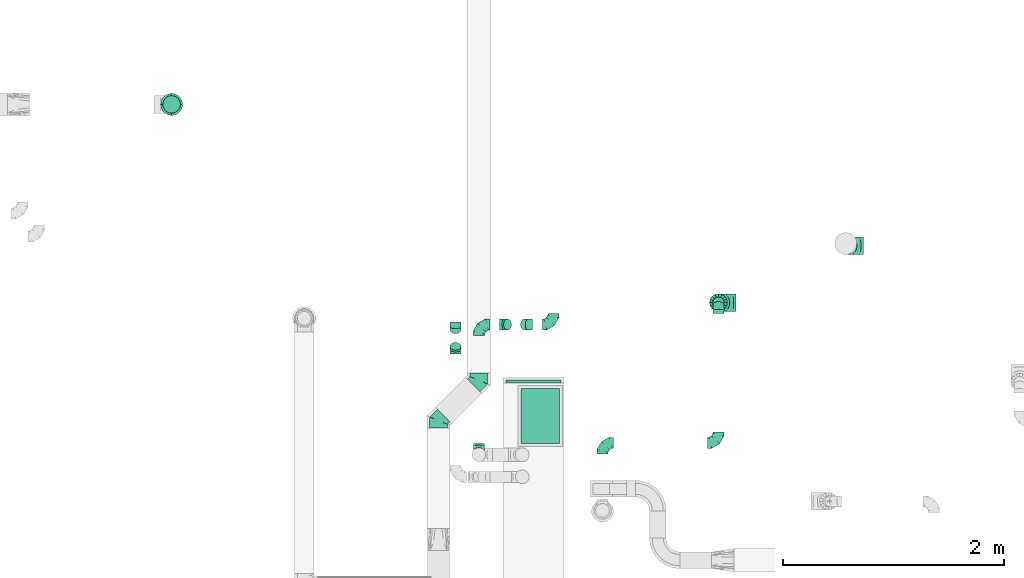
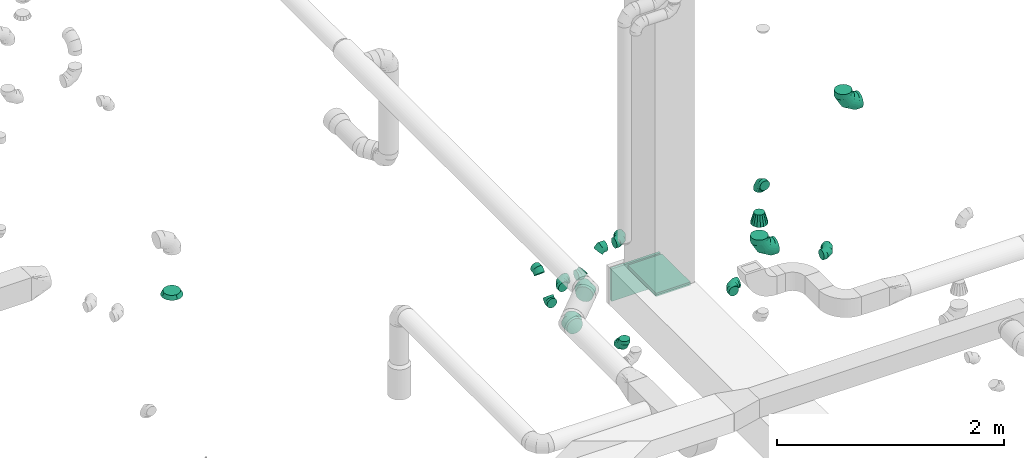
# One storey, part 76 of 97: 18 flow fittings.
"""IFC2X3 building model written with IfcOpenShell, lengths in millimetres."""

from ifc_helpers import new_model, entity, si_unit, converted_unit, derived_unit, direction, frame, origin, origin_2d_with_axis, place, context, subcontext, project, spatial, rectangle, extrude, faceted_brep, source, transform, mapped, material, type_object, type_shapes, element, save


model = new_model("IFC2X3")

# Units and contexts
model_context = context("Model", 3, precision=0.01, world=origin(), true_north=direction((6.12303176911189e-17, 1.0)))
body_context = subcontext(model_context, "Body", "Model", "MODEL_VIEW")
ifc_project = project(units=[si_unit("LENGTHUNIT", "METRE", prefix="MILLI"), si_unit("AREAUNIT", "SQUARE_METRE"), si_unit("VOLUMEUNIT", "CUBIC_METRE"), converted_unit("PLANEANGLEUNIT", "DEGREE", entity("IfcRatioMeasure", 0.0174532925199433), si_unit("PLANEANGLEUNIT", "RADIAN"), dimensions=[0, 0, 0, 0, 0, 0, 0]), si_unit("MASSUNIT", "GRAM", prefix="KILO"), derived_unit("MASSDENSITYUNIT", [(si_unit("MASSUNIT", "GRAM", prefix="KILO"), 1), (si_unit("LENGTHUNIT", "METRE"), -3)]), derived_unit("MOMENTOFINERTIAUNIT", [(si_unit("LENGTHUNIT", "METRE"), 4)]), si_unit("TIMEUNIT", "SECOND"), si_unit("FREQUENCYUNIT", "HERTZ"), si_unit("THERMODYNAMICTEMPERATUREUNIT", "DEGREE_CELSIUS"), derived_unit("THERMALTRANSMITTANCEUNIT", [(si_unit("MASSUNIT", "GRAM", prefix="KILO"), 1), (si_unit("THERMODYNAMICTEMPERATUREUNIT", "KELVIN"), -1), (si_unit("TIMEUNIT", "SECOND"), -3)]), derived_unit("VOLUMETRICFLOWRATEUNIT", [(si_unit("LENGTHUNIT", "METRE"), 3), (si_unit("TIMEUNIT", "SECOND"), -1)]), derived_unit("MASSFLOWRATEUNIT", [(si_unit("MASSUNIT", "GRAM", prefix="KILO"), 1), (si_unit("TIMEUNIT", "SECOND"), -1)]), derived_unit("ROTATIONALFREQUENCYUNIT", [(si_unit("TIMEUNIT", "SECOND"), -1)]), si_unit("ELECTRICCURRENTUNIT", "AMPERE"), si_unit("ELECTRICVOLTAGEUNIT", "VOLT"), si_unit("POWERUNIT", "WATT"), si_unit("FORCEUNIT", "NEWTON", prefix="KILO"), si_unit("ILLUMINANCEUNIT", "LUX"), si_unit("LUMINOUSFLUXUNIT", "LUMEN"), si_unit("LUMINOUSINTENSITYUNIT", "CANDELA"), derived_unit("USERDEFINED", [(si_unit("MASSUNIT", "GRAM", prefix="KILO"), -1), (si_unit("LENGTHUNIT", "METRE"), -2), (si_unit("TIMEUNIT", "SECOND"), 3), (si_unit("LUMINOUSFLUXUNIT", "LUMEN"), 1)]), derived_unit("LINEARVELOCITYUNIT", [(si_unit("LENGTHUNIT", "METRE"), 1), (si_unit("TIMEUNIT", "SECOND"), -1)]), si_unit("PRESSUREUNIT", "PASCAL"), derived_unit("USERDEFINED", [(si_unit("LENGTHUNIT", "METRE"), -2), (si_unit("MASSUNIT", "GRAM", prefix="KILO"), 1), (si_unit("TIMEUNIT", "SECOND"), -2)]), derived_unit("LINEARFORCEUNIT", [(si_unit("MASSUNIT", "GRAM", prefix="KILO"), 1), (si_unit("LENGTHUNIT", "METRE"), 1), (si_unit("TIMEUNIT", "SECOND"), -2), (si_unit("LENGTHUNIT", "METRE"), -1)]), derived_unit("PLANARFORCEUNIT", [(si_unit("MASSUNIT", "GRAM", prefix="KILO"), 1), (si_unit("LENGTHUNIT", "METRE"), 1), (si_unit("TIMEUNIT", "SECOND"), -2), (si_unit("LENGTHUNIT", "METRE"), -2)])], contexts=[model_context])

# Site, building, storey
site_placement = place(None, origin())
site = spatial("IfcSite", under=ifc_project, at=site_placement, CompositionType="ELEMENT")
building_placement = place(site_placement, origin())
building = spatial("IfcBuilding", under=site, at=building_placement, CompositionType="ELEMENT")
storey_placement = place(building_placement, frame((0.0, 0.0, -4900.0)))
storey = spatial("IfcBuildingStorey", under=building, at=storey_placement, CompositionType="ELEMENT", Elevation=-4900.0)

# Flow fittings
ifc_material = material()
duct_fitting_type_1 = type_object("IfcDuctFittingType", PredefinedType="NOTDEFINED", material=ifc_material)
shared_shape_1 = source(origin(), body_context, "Body", "SweptSolid", [
    extrude(rectangle(XDim=24.9999999999999, YDim=500.0, at=origin_2d_with_axis()), frame((12.5, 0.0, -175.0)), (0.0, 0.0, 1.0), 350.0),
])
type_shapes(duct_fitting_type_1, [shared_shape_1])
flow_fitting_1_placement = place(storey_placement, frame((67989.12, 12828.08, 3980.0), z_axis=(0.0, 0.0, 1.0), x_axis=(0.0, 1.0, 0.0)))
element("IfcFlowFitting", 1, at=flow_fitting_1_placement, inside=storey, type_object=duct_fitting_type_1, material=ifc_material, context=body_context, shape_type="MappedRepresentation", body=[
    mapped(shared_shape_1, transform((0.0, 0.0, 0.0), scale=1.0)),
])
duct_fitting_type_2 = type_object("IfcDuctFittingType", PredefinedType="NOTDEFINED", material=ifc_material)
shared_shape_2 = source(origin(), body_context, "Body", "SweptSolid", [
    extrude(rectangle(XDim=500.0, YDim=35.8775885811205, at=origin_2d_with_axis()), frame((6.95, 0.0, -175.0), z_axis=(0.0, 0.0, 1.0), x_axis=(0.0, -1.0, 0.0)), (0.0, 0.0, 1.0), 350.0),
])
type_shapes(duct_fitting_type_2, [shared_shape_2])
flow_fitting_2_placement = place(storey_placement, frame((68049.81, 12528.05, 4155.0), z_axis=(-1.0, 0.0, 0.0), x_axis=(0.0, 0.0, 1.0)))
element("IfcFlowFitting", 2, at=flow_fitting_2_placement, inside=storey, type_object=duct_fitting_type_2, material=ifc_material, context=body_context, shape_type="MappedRepresentation", body=[
    mapped(shared_shape_2, transform((0.0, 0.0, 0.0), scale=1.0)),
])
duct_fitting_type_3 = type_object("IfcDuctFittingType", PredefinedType="NOTDEFINED", material=ifc_material)
shared_shape_3 = source(origin(), body_context, "Body", "Brep", [
    faceted_brep([(-160.0, 0.0, -80.0), (-160.0, -20.71, -77.27), (-160.0, -40.0, -69.28), (-160.0, -56.57, -56.57), (-160.0, -69.28, -40.0), (-160.0, -77.27, -20.71), (-160.0, -80.0, 0.0), (-160.0, -77.27, 20.71), (-160.0, -69.28, 40.0), (-160.0, -56.57, 56.57), (-160.0, -40.0, 69.28), (-160.0, -20.71, 77.27), (-160.0, 0.0, 80.0), (-160.0, 20.71, 77.27), (-160.0, 40.0, 69.28), (-160.0, 56.57, 56.57), (-160.0, 69.28, 40.0), (-160.0, 77.27, 20.71), (-160.0, 80.0, 0.0), (-160.0, 77.27, -20.71), (-160.0, 69.28, -40.0), (-160.0, 56.57, -56.57), (-160.0, 40.0, -69.28), (-160.0, 20.71, -77.27), (-122.68, 20.71, 77.27), (-127.85, 40.0, 69.28), (-117.13, 0.0, 80.0), (-132.29, 56.57, 56.57), (-137.83, 77.27, 20.71), (-138.56, 80.0, 0.0), (-135.69, 69.28, 40.0), (-135.69, 69.28, -40.0), (-132.29, 56.57, -56.57), (-137.83, 77.27, -20.71), (-122.68, 20.71, -77.27), (-117.13, 0.0, -80.0), (-127.85, 40.0, -69.28), (-111.58, -20.71, -77.27), (-106.41, -40.0, -69.28), (-101.97, -56.57, -56.57), (-98.56, -69.28, -40.0), (-96.42, -77.27, -20.71), (-95.69, -80.0, 0.0), (-96.42, -77.27, 20.71), (-98.56, -69.28, 40.0), (-101.97, -56.57, 56.57), (-106.41, -40.0, 69.28), (-111.58, -20.71, 77.27), (-58.03, 58.03, 77.27), (-72.15, 72.15, 69.28), (-42.87, 42.87, 80.0), (-84.28, 84.28, 56.57), (-93.59, 93.59, 40.0), (-99.44, 99.44, 20.71), (-101.44, 101.44, 0.0), (-99.44, 99.44, -20.71), (-93.59, 93.59, -40.0), (-84.28, 84.28, -56.57), (-58.03, 58.03, -77.27), (-42.87, 42.87, -80.0), (-72.15, 72.15, -69.28), (-27.71, 27.71, -77.27), (-13.59, 13.59, -69.28), (-1.46, 1.46, -56.57), (7.85, -7.85, -40.0), (13.7, -13.7, -20.71), (15.69, -15.69, 0.0), (13.7, -13.7, 20.71), (7.85, -7.85, 40.0), (-1.46, 1.46, 56.57), (-13.59, 13.59, 69.28), (-27.71, 27.71, 77.27), (-20.71, 122.68, 77.27), (-40.0, 127.85, 69.28), (0.0, 117.13, 80.0), (-56.57, 132.29, 56.57), (-69.28, 135.69, 40.0), (-77.27, 137.83, 20.71), (-80.0, 138.56, 0.0), (-77.27, 137.83, -20.71), (-69.28, 135.69, -40.0), (-56.57, 132.29, -56.57), (-20.71, 122.68, -77.27), (0.0, 117.13, -80.0), (-40.0, 127.85, -69.28), (20.71, 111.58, -77.27), (40.0, 106.41, -69.28), (56.57, 101.97, -56.57), (69.28, 98.56, -40.0), (77.27, 96.42, -20.71), (80.0, 95.69, 0.0), (77.27, 96.42, 20.71), (69.28, 98.56, 40.0), (56.57, 101.97, 56.57), (40.0, 106.41, 69.28), (20.71, 111.58, 77.27), (-20.71, 160.0, -77.27), (-40.0, 160.0, -69.28), (-56.57, 160.0, -56.57), (-69.28, 160.0, -40.0), (-77.27, 160.0, -20.71), (-80.0, 160.0, 0.0), (-77.27, 160.0, 20.71), (-69.28, 160.0, 40.0), (-56.57, 160.0, 56.57), (-40.0, 160.0, 69.28), (-20.71, 160.0, 77.27), (0.0, 160.0, 80.0), (20.71, 160.0, 77.27), (40.0, 160.0, 69.28), (56.57, 160.0, 56.57), (69.28, 160.0, 40.0), (77.27, 160.0, 20.71), (80.0, 160.0, 0.0), (77.27, 160.0, -20.71), (69.28, 160.0, -40.0), (56.57, 160.0, -56.57), (40.0, 160.0, -69.28), (20.71, 160.0, -77.27), (0.0, 160.0, -80.0)], [[[0, 1, 2, 3, 4, 5, 6, 7, 8, 9, 10, 11, 12, 13, 14, 15, 16, 17, 18, 19, 20, 21, 22, 23]], [[24, 25, 14, 13]], [[26, 24, 13, 12]], [[14, 25, 27, 15]], [[28, 29, 18, 17]], [[30, 28, 17, 16]], [[15, 27, 30, 16]], [[20, 31, 32, 21]], [[33, 31, 20, 19]], [[18, 29, 33, 19]], [[34, 35, 0, 23]], [[36, 34, 23, 22]], [[32, 36, 22, 21]], [[1, 0, 35, 37]], [[2, 1, 37, 38]], [[3, 2, 38, 39]], [[5, 4, 40, 41]], [[6, 5, 41, 42]], [[39, 40, 4, 3]], [[6, 42, 43, 7]], [[7, 43, 44, 8]], [[8, 44, 45, 9]], [[9, 45, 46, 10]], [[10, 46, 47, 11]], [[26, 12, 11, 47]], [[48, 49, 25, 24]], [[50, 48, 24, 26]], [[27, 25, 49, 51]], [[52, 53, 28, 30]], [[51, 52, 30, 27]], [[29, 28, 53, 54]], [[55, 56, 31, 33]], [[54, 55, 33, 29]], [[32, 31, 56, 57]], [[58, 59, 35, 34]], [[60, 58, 34, 36]], [[57, 60, 36, 32]], [[37, 35, 59, 61]], [[38, 37, 61, 62]], [[39, 38, 62, 63]], [[41, 40, 64, 65]], [[42, 41, 65, 66]], [[63, 64, 40, 39]], [[43, 42, 66, 67]], [[44, 43, 67, 68]], [[68, 69, 45, 44]], [[46, 45, 69, 70]], [[47, 46, 70, 71]], [[26, 47, 71, 50]], [[72, 73, 49, 48]], [[74, 72, 48, 50]], [[51, 49, 73, 75]], [[76, 77, 53, 52]], [[75, 76, 52, 51]], [[54, 53, 77, 78]], [[79, 80, 56, 55]], [[78, 79, 55, 54]], [[57, 56, 80, 81]], [[82, 83, 59, 58]], [[84, 82, 58, 60]], [[81, 84, 60, 57]], [[61, 59, 83, 85]], [[62, 61, 85, 86]], [[63, 62, 86, 87]], [[65, 64, 88, 89]], [[66, 65, 89, 90]], [[87, 88, 64, 63]], [[67, 66, 90, 91]], [[68, 67, 91, 92]], [[92, 93, 69, 68]], [[70, 69, 93, 94]], [[71, 70, 94, 95]], [[50, 71, 95, 74]], [[96, 97, 98, 99, 100, 101, 102, 103, 104, 105, 106, 107, 108, 109, 110, 111, 112, 113, 114, 115, 116, 117, 118, 119]], [[72, 74, 107, 106]], [[73, 72, 106, 105]], [[75, 73, 105, 104]], [[77, 76, 103, 102]], [[78, 77, 102, 101]], [[75, 104, 103, 76]], [[78, 101, 100, 79]], [[79, 100, 99, 80]], [[80, 99, 98, 81]], [[84, 97, 96, 82]], [[82, 96, 119, 83]], [[84, 81, 98, 97]], [[118, 117, 86, 85]], [[119, 118, 85, 83]], [[116, 87, 86, 117]], [[88, 115, 114, 89]], [[89, 114, 113, 90]], [[115, 88, 87, 116]], [[112, 111, 92, 91]], [[113, 112, 91, 90]], [[111, 110, 93, 92]], [[95, 94, 109, 108]], [[74, 95, 108, 107]], [[110, 109, 94, 93]]]),
])
type_shapes(duct_fitting_type_3, [shared_shape_3])
for number, where, z_axis, x_axis in (
    (3, (69663.03, 13554.97, 3247.0), (0.0, -1.0, 0.0), (0.0, 0.0, -1.0)),
    (4, (70815.36, 14069.73, 4100.0), (0.0, 1.0, 0.0), (-1.0, 0.0, 0.0)),
):
    element("IfcFlowFitting", number, at=place(storey_placement, frame(where, z_axis=z_axis, x_axis=x_axis)), inside=storey, type_object=duct_fitting_type_3, material=ifc_material, context=body_context, shape_type="MappedRepresentation", body=[
        mapped(shared_shape_3, transform((0.0, 0.0, 0.0), scale=1.0)),
    ])
duct_fitting_type_4 = type_object("IfcDuctFittingType", PredefinedType="NOTDEFINED", material=ifc_material)
shared_shape_4 = source(origin(), body_context, "Body", "Brep", [
    faceted_brep([(40.0, -58.78, -80.9), (40.0, -30.9, -95.11), (40.0, 0.0, -100.0), (40.0, 30.9, -95.11), (40.0, 58.78, -80.9), (40.0, 80.9, -58.78), (40.0, 95.11, -30.9), (40.0, 100.0, 0.0), (40.0, 95.11, 30.9), (40.0, 80.9, 58.78), (40.0, 58.78, 80.9), (40.0, 30.9, 95.11), (40.0, 0.0, 100.0), (40.0, -30.9, 95.11), (40.0, -58.78, 80.9), (40.0, -80.9, 58.78), (40.0, -95.11, 30.9), (40.0, -100.0, 0.0), (40.0, -95.11, -30.9), (40.0, -80.9, -58.78), (0.0, -30.61, -73.91), (0.0, -43.59, -65.24), (0.0, -56.57, -56.57), (0.0, -65.24, -43.59), (0.0, -73.91, -30.61), (0.0, -76.96, -15.31), (0.0, -80.0, 0.0), (0.0, -76.96, 15.31), (0.0, -73.91, 30.61), (0.0, -65.24, 43.59), (0.0, -56.57, 56.57), (0.0, -43.59, 65.24), (0.0, -30.61, 73.91), (0.0, -15.31, 76.96), (0.0, 0.0, 80.0), (0.0, 15.31, 76.96), (0.0, 30.61, 73.91), (0.0, 43.59, 65.24), (0.0, 56.57, 56.57), (0.0, 65.24, 43.59), (0.0, 73.91, 30.61), (0.0, 76.96, 15.31), (0.0, 80.0, 0.0), (0.0, 76.96, -15.31), (0.0, 73.91, -30.61), (0.0, 65.24, -43.59), (0.0, 56.57, -56.57), (0.0, 43.59, -65.24), (0.0, 30.61, -73.91), (0.0, 15.31, -76.96), (0.0, 0.0, -80.0), (0.0, -15.31, -76.96)], [[[0, 1, 2, 3, 4, 5, 6, 7, 8, 9, 10, 11, 12, 13, 14, 15, 16, 17, 18, 19]], [[20, 21, 22, 23, 24, 25, 26, 27, 28, 29, 30, 31, 32, 33, 34, 35, 36, 37, 38, 39, 40, 41, 42, 43, 44, 45, 46, 47, 48, 49, 50, 51]], [[7, 41, 8]], [[40, 9, 8]], [[10, 38, 37, 36]], [[39, 38, 9, 40]], [[11, 36, 35]], [[34, 12, 35]], [[41, 40, 8]], [[10, 36, 11]], [[35, 12, 11]], [[41, 7, 42]], [[38, 10, 9]], [[12, 33, 13]], [[32, 14, 13]], [[15, 30, 29, 28]], [[31, 30, 14, 32]], [[16, 28, 27]], [[26, 17, 27]], [[33, 32, 13]], [[15, 28, 16]], [[27, 17, 16]], [[33, 12, 34]], [[30, 15, 14]], [[17, 25, 18]], [[24, 19, 18]], [[0, 22, 21, 20]], [[23, 22, 19, 24]], [[1, 20, 51]], [[50, 2, 51]], [[25, 24, 18]], [[0, 20, 1]], [[51, 2, 1]], [[25, 17, 26]], [[22, 0, 19]], [[2, 49, 3]], [[48, 4, 3]], [[5, 46, 45, 44]], [[47, 46, 4, 48]], [[6, 44, 43]], [[42, 7, 43]], [[49, 48, 3]], [[5, 44, 6]], [[43, 7, 6]], [[49, 2, 50]], [[46, 5, 4]]]),
])
type_shapes(duct_fitting_type_4, [shared_shape_4])
flow_fitting_3_placement = place(storey_placement, frame((64713.68, 15348.96, 3456.99), z_axis=(0.0, -1.0, 0.0), x_axis=(0.0, 0.0, -1.0)))
element("IfcFlowFitting", 5, at=flow_fitting_3_placement, inside=storey, type_object=duct_fitting_type_4, material=ifc_material, context=body_context, shape_type="MappedRepresentation", body=[
    mapped(shared_shape_4, transform((0.0, 0.0, 0.0), scale=1.0)),
])
duct_fitting_type_5 = type_object("IfcDuctFittingType", PredefinedType="NOTDEFINED", material=ifc_material)
shared_shape_5 = source(origin(), body_context, "Body", "Brep", [
    faceted_brep([(-100.0, 0.0, -50.0), (-100.0, -12.94, -48.3), (-100.0, -25.0, -43.3), (-100.0, -35.36, -35.36), (-100.0, -43.3, -25.0), (-100.0, -48.3, -12.94), (-100.0, -50.0, 0.0), (-100.0, -48.3, 12.94), (-100.0, -43.3, 25.0), (-100.0, -35.36, 35.36), (-100.0, -25.0, 43.3), (-100.0, -12.94, 48.3), (-100.0, 0.0, 50.0), (-100.0, 12.94, 48.3), (-100.0, 25.0, 43.3), (-100.0, 35.36, 35.36), (-100.0, 43.3, 25.0), (-100.0, 48.3, 12.94), (-100.0, 50.0, 0.0), (-100.0, 48.3, -12.94), (-100.0, 43.3, -25.0), (-100.0, 35.36, -35.36), (-100.0, 25.0, -43.3), (-100.0, 12.94, -48.3), (-76.67, 12.94, 48.3), (-79.9, 25.0, 43.3), (-73.21, 0.0, 50.0), (-82.68, 35.36, 35.36), (-86.15, 48.3, 12.94), (-86.6, 50.0, 0.0), (-84.81, 43.3, 25.0), (-84.81, 43.3, -25.0), (-82.68, 35.36, -35.36), (-86.15, 48.3, -12.94), (-76.67, 12.94, -48.3), (-73.21, 0.0, -50.0), (-79.9, 25.0, -43.3), (-69.74, -12.94, -48.3), (-66.51, -25.0, -43.3), (-63.73, -35.36, -35.36), (-61.6, -43.3, -25.0), (-60.26, -48.3, -12.94), (-59.81, -50.0, 0.0), (-60.26, -48.3, 12.94), (-61.6, -43.3, 25.0), (-63.73, -35.36, 35.36), (-66.51, -25.0, 43.3), (-69.74, -12.94, 48.3), (-36.27, 36.27, 48.3), (-45.1, 45.1, 43.3), (-26.79, 26.79, 50.0), (-52.68, 52.68, 35.36), (-58.49, 58.49, 25.0), (-62.15, 62.15, 12.94), (-63.4, 63.4, 0.0), (-62.15, 62.15, -12.94), (-58.49, 58.49, -25.0), (-52.68, 52.68, -35.36), (-36.27, 36.27, -48.3), (-26.79, 26.79, -50.0), (-45.1, 45.1, -43.3), (-17.32, 17.32, -48.3), (-8.49, 8.49, -43.3), (-0.91, 0.91, -35.36), (4.9, -4.9, -25.0), (8.56, -8.56, -12.94), (9.81, -9.81, 0.0), (8.56, -8.56, 12.94), (4.9, -4.9, 25.0), (-0.91, 0.91, 35.36), (-8.49, 8.49, 43.3), (-17.32, 17.32, 48.3), (-12.94, 76.67, 48.3), (-25.0, 79.9, 43.3), (0.0, 73.21, 50.0), (-35.36, 82.68, 35.36), (-43.3, 84.81, 25.0), (-48.3, 86.15, 12.94), (-50.0, 86.6, 0.0), (-48.3, 86.15, -12.94), (-43.3, 84.81, -25.0), (-35.36, 82.68, -35.36), (-12.94, 76.67, -48.3), (0.0, 73.21, -50.0), (-25.0, 79.9, -43.3), (12.94, 69.74, -48.3), (25.0, 66.51, -43.3), (35.36, 63.73, -35.36), (43.3, 61.6, -25.0), (48.3, 60.26, -12.94), (50.0, 59.81, 0.0), (48.3, 60.26, 12.94), (43.3, 61.6, 25.0), (35.36, 63.73, 35.36), (25.0, 66.51, 43.3), (12.94, 69.74, 48.3), (-12.94, 100.0, -48.3), (-25.0, 100.0, -43.3), (-35.36, 100.0, -35.36), (-43.3, 100.0, -25.0), (-48.3, 100.0, -12.94), (-50.0, 100.0, 0.0), (-48.3, 100.0, 12.94), (-43.3, 100.0, 25.0), (-35.36, 100.0, 35.36), (-25.0, 100.0, 43.3), (-12.94, 100.0, 48.3), (0.0, 100.0, 50.0), (12.94, 100.0, 48.3), (25.0, 100.0, 43.3), (35.36, 100.0, 35.36), (43.3, 100.0, 25.0), (48.3, 100.0, 12.94), (50.0, 100.0, 0.0), (48.3, 100.0, -12.94), (43.3, 100.0, -25.0), (35.36, 100.0, -35.36), (25.0, 100.0, -43.3), (12.94, 100.0, -48.3), (0.0, 100.0, -50.0)], [[[0, 1, 2, 3, 4, 5, 6, 7, 8, 9, 10, 11, 12, 13, 14, 15, 16, 17, 18, 19, 20, 21, 22, 23]], [[24, 25, 14, 13]], [[26, 24, 13, 12]], [[14, 25, 27, 15]], [[28, 29, 18, 17]], [[30, 28, 17, 16]], [[15, 27, 30, 16]], [[20, 31, 32, 21]], [[33, 31, 20, 19]], [[18, 29, 33, 19]], [[34, 35, 0, 23]], [[36, 34, 23, 22]], [[32, 36, 22, 21]], [[2, 1, 37, 38]], [[3, 2, 38, 39]], [[0, 35, 37, 1]], [[5, 4, 40, 41]], [[6, 5, 41, 42]], [[3, 39, 40, 4]], [[6, 42, 43, 7]], [[7, 43, 44, 8]], [[8, 44, 45, 9]], [[10, 46, 47, 11]], [[11, 47, 26, 12]], [[10, 9, 45, 46]], [[48, 49, 25, 24]], [[50, 48, 24, 26]], [[27, 25, 49, 51]], [[52, 53, 28, 30]], [[51, 52, 30, 27]], [[29, 28, 53, 54]], [[55, 56, 31, 33]], [[54, 55, 33, 29]], [[57, 32, 31, 56]], [[58, 59, 35, 34]], [[60, 58, 34, 36]], [[57, 60, 36, 32]], [[37, 35, 59, 61]], [[38, 37, 61, 62]], [[39, 38, 62, 63]], [[41, 40, 64, 65]], [[42, 41, 65, 66]], [[63, 64, 40, 39]], [[43, 42, 66, 67]], [[44, 43, 67, 68]], [[68, 69, 45, 44]], [[46, 45, 69, 70]], [[47, 46, 70, 71]], [[26, 47, 71, 50]], [[72, 73, 49, 48]], [[74, 72, 48, 50]], [[51, 49, 73, 75]], [[76, 77, 53, 52]], [[75, 76, 52, 51]], [[54, 53, 77, 78]], [[79, 80, 56, 55]], [[78, 79, 55, 54]], [[81, 57, 56, 80]], [[82, 83, 59, 58]], [[84, 82, 58, 60]], [[81, 84, 60, 57]], [[61, 59, 83, 85]], [[62, 61, 85, 86]], [[63, 62, 86, 87]], [[65, 64, 88, 89]], [[66, 65, 89, 90]], [[87, 88, 64, 63]], [[67, 66, 90, 91]], [[68, 67, 91, 92]], [[92, 93, 69, 68]], [[70, 69, 93, 94]], [[71, 70, 94, 95]], [[50, 71, 95, 74]], [[96, 97, 98, 99, 100, 101, 102, 103, 104, 105, 106, 107, 108, 109, 110, 111, 112, 113, 114, 115, 116, 117, 118, 119]], [[72, 74, 107, 106]], [[73, 72, 106, 105]], [[75, 73, 105, 104]], [[77, 76, 103, 102]], [[78, 77, 102, 101]], [[75, 104, 103, 76]], [[78, 101, 100, 79]], [[79, 100, 99, 80]], [[80, 99, 98, 81]], [[96, 119, 83, 82]], [[97, 96, 82, 84]], [[84, 81, 98, 97]], [[83, 119, 118, 85]], [[85, 118, 117, 86]], [[86, 117, 116, 87]], [[88, 115, 114, 89]], [[89, 114, 113, 90]], [[87, 116, 115, 88]], [[91, 90, 113, 112]], [[92, 91, 112, 111]], [[93, 92, 111, 110]], [[95, 94, 109, 108]], [[74, 95, 108, 107]], [[110, 109, 94, 93]]]),
])
type_shapes(duct_fitting_type_5, [shared_shape_5])
flow_fitting_4_placement = place(storey_placement, frame((68613.63, 12285.94, 4000.0), z_axis=(0.0, 0.0, 1.0), x_axis=(-1.0, 0.0, 0.0)))
element("IfcFlowFitting", 6, at=flow_fitting_4_placement, inside=storey, type_object=duct_fitting_type_5, material=ifc_material, context=body_context, shape_type="MappedRepresentation", body=[
    mapped(shared_shape_5, transform((0.0, 0.0, 0.0), scale=1.0)),
])
flow_fitting_5_placement = place(storey_placement, frame((69663.03, 12285.94, 4000.0)))
element("IfcFlowFitting", 7, at=flow_fitting_5_placement, inside=storey, type_object=duct_fitting_type_5, material=ifc_material, context=body_context, shape_type="MappedRepresentation", body=[
    mapped(shared_shape_5, transform((0.0, 0.0, 0.0), scale=1.0)),
])
for number, where, z_axis, x_axis in (
    (8, (69663.03, 13554.97, 4000.0), (-1.0, 0.0, 0.0), (0.0, 1.0, 0.0)),
    (9, (67494.25, 12178.74, 3787.66), (-1.0, 0.0, 0.0), (0.0, -1.0, 0.0)),
    (10, (67494.25, 13356.7, 3787.66), (0.0, 0.0, 1.0), (-1.0, 0.0, 0.0)),
):
    element("IfcFlowFitting", number, at=place(storey_placement, frame(where, z_axis=z_axis, x_axis=x_axis)), inside=storey, type_object=duct_fitting_type_5, material=ifc_material, context=body_context, shape_type="MappedRepresentation", body=[
        mapped(shared_shape_5, transform((0.0, 0.0, 0.0), scale=1.0)),
    ])
flow_fitting_6_placement = place(storey_placement, frame((68169.32, 13356.7, 4000.0)))
element("IfcFlowFitting", 11, at=flow_fitting_6_placement, inside=storey, type_object=duct_fitting_type_5, material=ifc_material, context=body_context, shape_type="MappedRepresentation", body=[
    mapped(shared_shape_5, transform((0.0, 0.0, 0.0), scale=1.0)),
])
duct_fitting_type_6 = type_object("IfcDuctFittingType", PredefinedType="NOTDEFINED", material=ifc_material)
shared_shape_6 = source(origin(), body_context, "Body", "Brep", [
    faceted_brep([(-66.27, 0.0, -80.0), (-66.27, -20.71, -77.27), (-66.27, -40.0, -69.28), (-66.27, -56.57, -56.57), (-66.27, -69.28, -40.0), (-66.27, -77.27, -20.71), (-66.27, -80.0, 0.0), (-66.27, -77.27, 20.71), (-66.27, -69.28, 40.0), (-66.27, -56.57, 56.57), (-66.27, -40.0, 69.28), (-66.27, -20.71, 77.27), (-66.27, 0.0, 80.0), (-66.27, 20.71, 77.27), (-66.27, 40.0, 69.28), (-66.27, 56.57, 56.57), (-66.27, 69.28, 40.0), (-66.27, 77.27, 20.71), (-66.27, 80.0, 0.0), (-66.27, 77.27, -20.71), (-66.27, 69.28, -40.0), (-66.27, 56.57, -56.57), (-66.27, 40.0, -69.28), (-66.27, 20.71, -77.27), (-8.58, 20.71, 77.27), (-16.57, 40.0, 69.28), (0.0, 0.0, 80.0), (-23.43, 56.57, 56.57), (-28.7, 69.28, 40.0), (-32.01, 77.27, 20.71), (-33.14, 80.0, 0.0), (-32.01, 77.27, -20.71), (-28.7, 69.28, -40.0), (-23.43, 56.57, -56.57), (-8.58, 20.71, -77.27), (0.0, 0.0, -80.0), (-16.57, 40.0, -69.28), (8.58, -20.71, -77.27), (16.57, -40.0, -69.28), (23.43, -56.57, -56.57), (28.7, -69.28, -40.0), (32.01, -77.27, -20.71), (33.14, -80.0, 0.0), (32.01, -77.27, 20.71), (28.7, -69.28, 40.0), (23.43, -56.57, 56.57), (16.57, -40.0, 69.28), (8.58, -20.71, 77.27), (46.86, 46.86, 80.0), (32.22, 61.5, 77.27), (18.58, 75.15, 69.28), (6.86, 86.86, 56.57), (-2.13, 95.85, 40.0), (-7.78, 101.5, 20.71), (-9.71, 103.43, 0.0), (-7.78, 101.5, -20.71), (-2.13, 95.85, -40.0), (6.86, 86.86, -56.57), (18.58, 75.15, -69.28), (32.22, 61.5, -77.27), (46.86, 46.86, -80.0), (61.5, 32.22, -77.27), (75.15, 18.58, -69.28), (86.86, 6.86, -56.57), (95.85, -2.13, -40.0), (101.5, -7.78, -20.71), (103.43, -9.71, 0.0), (101.5, -7.78, 20.71), (95.85, -2.13, 40.0), (86.86, 6.86, 56.57), (75.15, 18.58, 69.28), (61.5, 32.22, 77.27)], [[[0, 1, 2, 3, 4, 5, 6, 7, 8, 9, 10, 11, 12, 13, 14, 15, 16, 17, 18, 19, 20, 21, 22, 23]], [[24, 25, 14, 13]], [[26, 24, 13, 12]], [[14, 25, 27, 15]], [[28, 29, 17, 16]], [[28, 16, 15, 27]], [[30, 18, 17, 29]], [[31, 32, 20, 19]], [[30, 31, 19, 18]], [[32, 33, 21, 20]], [[34, 35, 0, 23]], [[36, 34, 23, 22]], [[33, 36, 22, 21]], [[1, 0, 35, 37]], [[2, 1, 37, 38]], [[38, 39, 3, 2]], [[5, 4, 40, 41]], [[6, 5, 41, 42]], [[39, 40, 4, 3]], [[6, 42, 43, 7]], [[7, 43, 44, 8]], [[8, 44, 45, 9]], [[9, 45, 46, 10]], [[10, 46, 47, 11]], [[26, 12, 11, 47]], [[24, 26, 48, 49]], [[25, 24, 49, 50]], [[27, 25, 50, 51]], [[29, 28, 52, 53]], [[30, 29, 53, 54]], [[51, 52, 28, 27]], [[30, 54, 55, 31]], [[31, 55, 56, 32]], [[57, 33, 32, 56]], [[36, 58, 59, 34]], [[34, 59, 60, 35]], [[58, 36, 33, 57]], [[35, 60, 61, 37]], [[37, 61, 62, 38]], [[63, 39, 38, 62]], [[40, 64, 65, 41]], [[41, 65, 66, 42]], [[64, 40, 39, 63]], [[43, 42, 66, 67]], [[44, 43, 67, 68]], [[68, 69, 45, 44]], [[47, 46, 70, 71]], [[26, 47, 71, 48]], [[69, 70, 46, 45]], [[59, 58, 57, 56, 55, 54, 53, 52, 51, 50, 49, 48, 71, 70, 69, 68, 67, 66, 65, 64, 63, 62, 61, 60]]]),
])
type_shapes(duct_fitting_type_6, [shared_shape_6])
for number, where, z_axis, x_axis in (
    (12, (67129.73, 12487.06, 4000.0), (0.0, 0.0, 1.0), (-0.707106781186548, -0.707106781186548, 0.0)),
    (13, (67494.2, 12851.54, 4000.0), (0.0, 0.0, 1.0), (0.707106781186558, 0.707106781186537, 0.0)),
):
    element("IfcFlowFitting", number, at=place(storey_placement, frame(where, z_axis=z_axis, x_axis=x_axis)), inside=storey, type_object=duct_fitting_type_6, material=ifc_material, context=body_context, shape_type="MappedRepresentation", body=[
        mapped(shared_shape_6, transform((0.0, 0.0, 0.0), scale=1.0)),
    ])
duct_fitting_type_7 = type_object("IfcDuctFittingType", PredefinedType="NOTDEFINED", material=ifc_material)
shared_shape_7 = source(origin(), body_context, "Body", "Brep", [
    faceted_brep([(112.0, -16.52, -76.71), (112.0, 0.0, -80.0), (112.0, 16.52, -76.71), (112.0, 30.61, -73.91), (112.0, 43.59, -65.24), (112.0, 56.57, -56.57), (112.0, 65.24, -43.59), (112.0, 73.91, -30.61), (112.0, 76.71, -16.52), (112.0, 80.0, 0.0), (112.0, 76.71, 16.52), (112.0, 73.91, 30.61), (112.0, 65.24, 43.59), (112.0, 56.57, 56.57), (112.0, 43.59, 65.24), (112.0, 30.61, 73.91), (112.0, 16.52, 76.71), (112.0, 0.0, 80.0), (112.0, -16.52, 76.71), (112.0, -30.61, 73.91), (112.0, -43.59, 65.24), (112.0, -56.57, 56.57), (112.0, -65.24, 43.59), (112.0, -73.91, 30.61), (112.0, -76.71, 16.52), (112.0, -80.0, 0.0), (112.0, -76.71, -16.52), (112.0, -73.91, -30.61), (112.0, -65.24, -43.59), (112.0, -56.57, -56.57), (112.0, -43.59, -65.24), (112.0, -30.61, -73.91), (0.0, 0.0, 50.0), (0.0, 9.57, 48.1), (0.0, 19.13, 46.19), (0.0, 27.24, 40.77), (0.0, 35.36, 35.36), (0.0, 40.77, 27.24), (0.0, 46.19, 19.13), (0.0, 48.1, 9.57), (0.0, 50.0, 0.0), (0.0, 48.1, -9.57), (0.0, 46.19, -19.13), (0.0, 40.77, -27.24), (0.0, 35.36, -35.36), (0.0, 27.24, -40.77), (0.0, 19.13, -46.19), (0.0, 9.57, -48.1), (0.0, 0.0, -50.0), (0.0, -9.57, -48.1), (0.0, -19.13, -46.19), (0.0, -27.24, -40.77), (0.0, -35.36, -35.36), (0.0, -40.77, -27.24), (0.0, -46.19, -19.13), (0.0, -48.1, -9.57), (0.0, -50.0, 0.0), (0.0, -48.1, 9.57), (0.0, -46.19, 19.13), (0.0, -40.77, 27.24), (0.0, -35.36, 35.36), (0.0, -27.24, 40.77), (0.0, -19.13, 46.19), (0.0, -9.57, 48.1)], [[[0, 1, 2, 3, 4, 5, 6, 7, 8, 9, 10, 11, 12, 13, 14, 15, 16, 17, 18, 19, 20, 21, 22, 23, 24, 25, 26, 27, 28, 29, 30, 31]], [[32, 33, 34, 35, 36, 37, 38, 39, 40, 41, 42, 43, 44, 45, 46, 47, 48, 49, 50, 51, 52, 53, 54, 55, 56, 57, 58, 59, 60, 61, 62, 63]], [[38, 11, 10, 9, 40, 39]], [[36, 13, 12, 11, 38, 37]], [[33, 32, 17, 16, 15, 34]], [[13, 36, 35, 34, 15, 14]], [[62, 19, 18, 17, 32, 63]], [[60, 21, 20, 19, 62, 61]], [[57, 56, 25, 24, 23, 58]], [[21, 60, 59, 58, 23, 22]], [[54, 27, 26, 25, 56, 55]], [[52, 29, 28, 27, 54, 53]], [[49, 48, 1, 0, 31, 50]], [[29, 52, 51, 50, 31, 30]], [[46, 3, 2, 1, 48, 47]], [[44, 5, 4, 3, 46, 45]], [[41, 40, 9, 8, 7, 42]], [[5, 44, 43, 42, 7, 6]]]),
])
type_shapes(duct_fitting_type_7, [shared_shape_7])
flow_fitting_7_placement = place(storey_placement, frame((69663.03, 13554.97, 3656.01), z_axis=(0.0, -1.0, 0.0), x_axis=(0.0, 0.0, -1.0)))
element("IfcFlowFitting", 14, at=flow_fitting_7_placement, inside=storey, type_object=duct_fitting_type_7, material=ifc_material, context=body_context, shape_type="MappedRepresentation", body=[
    mapped(shared_shape_7, transform((0.0, 0.0, 0.0), scale=1.0)),
])
duct_fitting_type_8 = type_object("IfcDuctFittingType", PredefinedType="NOTDEFINED", material=ifc_material)
shared_shape_8 = source(origin(), body_context, "Body", "Brep", [
    faceted_brep([(-41.42, 0.0, -50.0), (-41.42, -12.94, -48.3), (-41.42, -25.0, -43.3), (-41.42, -35.36, -35.36), (-41.42, -43.3, -25.0), (-41.42, -48.3, -12.94), (-41.42, -50.0, 0.0), (-41.42, -48.3, 12.94), (-41.42, -43.3, 25.0), (-41.42, -35.36, 35.36), (-41.42, -25.0, 43.3), (-41.42, -12.94, 48.3), (-41.42, 0.0, 50.0), (-41.42, 12.94, 48.3), (-41.42, 25.0, 43.3), (-41.42, 35.36, 35.36), (-41.42, 43.3, 25.0), (-41.42, 48.3, 12.94), (-41.42, 50.0, 0.0), (-41.42, 48.3, -12.94), (-41.42, 43.3, -25.0), (-41.42, 35.36, -35.36), (-41.42, 25.0, -43.3), (-41.42, 12.94, -48.3), (-5.36, 12.94, 48.3), (-10.36, 25.0, 43.3), (0.0, 0.0, 50.0), (-14.64, 35.36, 35.36), (-20.0, 48.3, 12.94), (-20.71, 50.0, 0.0), (-17.94, 43.3, 25.0), (-17.94, 43.3, -25.0), (-14.64, 35.36, -35.36), (-20.0, 48.3, -12.94), (-5.36, 12.94, -48.3), (0.0, 0.0, -50.0), (-10.36, 25.0, -43.3), (5.36, -12.94, -48.3), (10.36, -25.0, -43.3), (14.64, -35.36, -35.36), (17.94, -43.3, -25.0), (20.0, -48.3, -12.94), (20.71, -50.0, 0.0), (20.0, -48.3, 12.94), (17.94, -43.3, 25.0), (14.64, -35.36, 35.36), (10.36, -25.0, 43.3), (5.36, -12.94, 48.3), (29.29, 29.29, 50.0), (20.14, 38.44, 48.3), (11.61, 46.97, 43.3), (4.29, 54.29, 35.36), (-1.33, 59.91, 25.0), (-4.86, 63.44, 12.94), (-6.07, 64.64, 0.0), (-4.86, 63.44, -12.94), (-1.33, 59.91, -25.0), (4.29, 54.29, -35.36), (11.61, 46.97, -43.3), (20.14, 38.44, -48.3), (29.29, 29.29, -50.0), (38.44, 20.14, -48.3), (46.97, 11.61, -43.3), (54.29, 4.29, -35.36), (59.91, -1.33, -25.0), (63.44, -4.86, -12.94), (64.64, -6.07, 0.0), (63.44, -4.86, 12.94), (59.91, -1.33, 25.0), (54.29, 4.29, 35.36), (46.97, 11.61, 43.3), (38.44, 20.14, 48.3)], [[[0, 1, 2, 3, 4, 5, 6, 7, 8, 9, 10, 11, 12, 13, 14, 15, 16, 17, 18, 19, 20, 21, 22, 23]], [[24, 25, 14, 13]], [[26, 24, 13, 12]], [[14, 25, 27, 15]], [[28, 29, 18, 17]], [[30, 28, 17, 16]], [[16, 15, 27, 30]], [[20, 31, 32, 21]], [[33, 31, 20, 19]], [[18, 29, 33, 19]], [[34, 35, 0, 23]], [[36, 34, 23, 22]], [[32, 36, 22, 21]], [[1, 0, 35, 37]], [[2, 1, 37, 38]], [[38, 39, 3, 2]], [[5, 4, 40, 41]], [[6, 5, 41, 42]], [[39, 40, 4, 3]], [[6, 42, 43, 7]], [[7, 43, 44, 8]], [[8, 44, 45, 9]], [[9, 45, 46, 10]], [[10, 46, 47, 11]], [[26, 12, 11, 47]], [[24, 26, 48, 49]], [[25, 24, 49, 50]], [[27, 25, 50, 51]], [[28, 30, 52, 53]], [[29, 28, 53, 54]], [[27, 51, 52, 30]], [[29, 54, 55, 33]], [[33, 55, 56, 31]], [[31, 56, 57, 32]], [[36, 58, 59, 34]], [[34, 59, 60, 35]], [[36, 32, 57, 58]], [[61, 62, 38, 37]], [[60, 61, 37, 35]], [[63, 39, 38, 62]], [[40, 64, 65, 41]], [[41, 65, 66, 42]], [[64, 40, 39, 63]], [[43, 42, 66, 67]], [[44, 43, 67, 68]], [[68, 69, 45, 44]], [[47, 46, 70, 71]], [[26, 47, 71, 48]], [[69, 70, 46, 45]], [[59, 58, 57, 56, 55, 54, 53, 52, 51, 50, 49, 48, 71, 70, 69, 68, 67, 66, 65, 64, 63, 62, 61, 60]]]),
])
type_shapes(duct_fitting_type_8, [shared_shape_8])
for number, where, z_axis, x_axis in (
    (15, (67282.28, 13129.42, 3790.0), (1.0, 0.0, 0.0), (0.0, 1.0, 0.0)),
    (16, (67282.28, 13339.42, 4000.0), (-1.0, 0.0, 0.0), (0.0, 0.707106781186525, 0.70710678118657)),
    (17, (67724.44, 13356.7, 3787.66), (0.0, -1.0, 0.0), (1.0, 0.0, 0.0)),
    (18, (67936.79, 13356.7, 4000.0), (0.0, 1.0, 0.0), (0.707106781186484, 0.0, 0.707106781186611)),
):
    element("IfcFlowFitting", number, at=place(storey_placement, frame(where, z_axis=z_axis, x_axis=x_axis)), inside=storey, type_object=duct_fitting_type_8, material=ifc_material, context=body_context, shape_type="MappedRepresentation", body=[
        mapped(shared_shape_8, transform((0.0, 0.0, 0.0), scale=1.0)),
    ])

save(model, "model.ifc")
